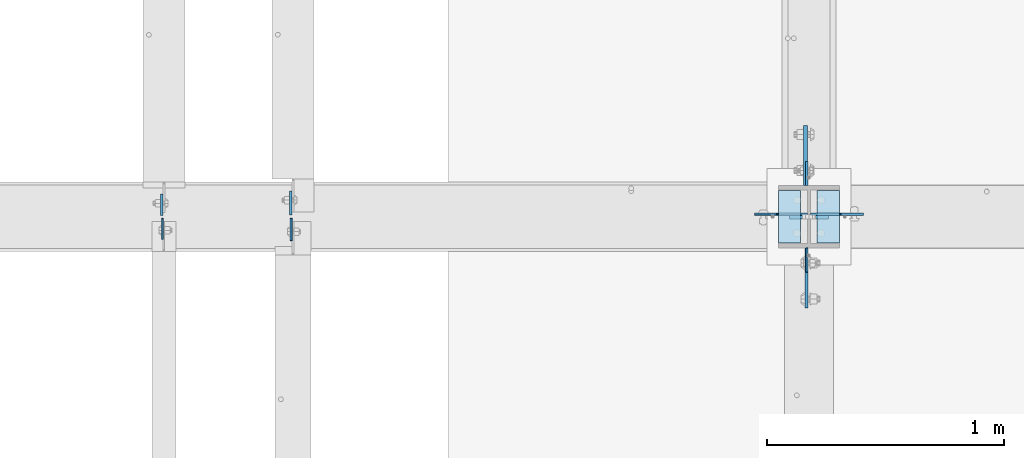
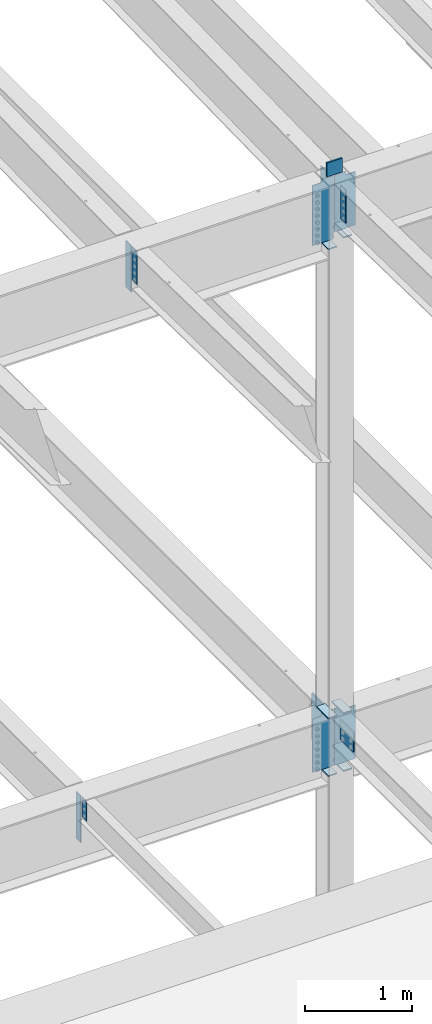
# One storey, part 1544 of 1763: 19 plates, 3 elements without a shape of their own.
"""IFC2X3 building model written with IfcOpenShell, lengths in millimetres."""

from ifc_helpers import new_model, si_unit, frame, origin_with_axes, place, context, subcontext, project, spatial, faceted_brep, material, type_object, element, aggregate, save


model = new_model("IFC2X3")

# Units and contexts
model_context = context("Model", 3, precision=1e-05, world=origin_with_axes())
body_context = subcontext(model_context, "Body", "Model", "MODEL_VIEW")
ifc_project = project(units=[si_unit("LENGTHUNIT", "METRE", prefix="MILLI"), si_unit("AREAUNIT", "SQUARE_METRE"), si_unit("VOLUMEUNIT", "CUBIC_METRE"), si_unit("MASSUNIT", "GRAM", prefix="KILO"), si_unit("TIMEUNIT", "SECOND"), si_unit("PLANEANGLEUNIT", "RADIAN"), si_unit("SOLIDANGLEUNIT", "STERADIAN"), si_unit("THERMODYNAMICTEMPERATUREUNIT", "DEGREE_CELSIUS"), si_unit("LUMINOUSINTENSITYUNIT", "LUMEN")], contexts=[model_context])

# Site, building, storey
site_placement = place(None, origin_with_axes())
site = spatial("IfcSite", under=ifc_project, at=site_placement, CompositionType="ELEMENT")
building_placement = place(site_placement, origin_with_axes())
building = spatial("IfcBuilding", under=site, at=building_placement, Name="Undefined", CompositionType="ELEMENT")
storey_placement = place(building_placement, origin_with_axes())
storey = spatial("IfcBuildingStorey", under=building, at=storey_placement, Name="Undefined", CompositionType="ELEMENT", Elevation=0.0)

# Assembly, plate
assembly_1_placement = place(storey_placement, origin_with_axes())
assembly_1 = element("IfcElementAssembly", 1, at=assembly_1_placement, inside=storey, Name="COLUMN", AssemblyPlace="NOTDEFINED", PredefinedType="RIGID_FRAME")
ifc_material_1 = material(Name="STEEL/A36")
plate_type_1 = type_object("IfcPlateType", PredefinedType="NOTDEFINED")
plate_1_placement = place(assembly_1_placement, frame((-61602.3750236983, 29891.0374999998, 11256.2654896847), z_axis=(0.0, -1.0, 0.0), x_axis=(0.0, 0.0, -1.0)))
plate_1 = element("IfcPlate", 2, at=plate_1_placement, type_object=plate_type_1, material=ifc_material_1, Name="PLATE", context=body_context, shape_type="Brep", body=[
    faceted_brep([(0.0, -3.96900000000096, 0.0), (-1.18234311230481e-11, -3.96900000000096, 101.599998474121), (-1.18234311230481e-11, 3.96900000000096, 101.599998474121), (0.0, 3.96900000000096, 0.0), (381.0, -3.96899999999732, 101.599998474121), (381.0, 3.96899999999732, 101.599998474121), (381.0, -3.96900000001915, 3.34694050252438e-10), (381.0, 3.9690000000046, 3.20142135024071e-10)], [[[0, 1, 2, 3]], [[1, 4, 5, 2]], [[4, 6, 7, 5]], [[6, 0, 3, 7]], [[5, 7, 3, 2]], [[6, 4, 1, 0]]]),
])

# Assembly, plates
assembly_2_placement = place(storey_placement, origin_with_axes())
assembly_2 = element("IfcElementAssembly", 3, at=assembly_2_placement, inside=storey, Name="BEAM", AssemblyPlace="NOTDEFINED", PredefinedType="RIGID_FRAME")
plate_type_2 = type_object("IfcPlateType", PredefinedType="NOTDEFINED")
plate_2_placement = place(assembly_2_placement, frame((-64328.1122736983, 30029.15, 5143.5), z_axis=(0.0, 1.0, 0.0), x_axis=(0.0, 0.0, -1.0)))
plate_2 = element("IfcPlate", 4, at=plate_2_placement, type_object=plate_type_2, material=ifc_material_1, Name="PLATE", context=body_context, shape_type="Brep", body=[
    faceted_brep([(0.0, -4.76249999999982, 0.0), (0.0, -4.76250000000073, 88.9000015258789), (0.0, 4.76250000000073, 88.9000015258789), (0.0, 4.76249999999982, 0.0), (533.400024414062, -4.76250000000073, 88.9000015258789), (533.400024414062, 4.76250000000073, 88.9000015258789), (533.400024414062, -4.76250000000073, 0.0), (533.400024414062, 4.76250000000073, 0.0)], [[[0, 1, 2, 3]], [[1, 4, 5, 2]], [[4, 6, 7, 5]], [[6, 0, 3, 7]], [[5, 7, 3, 2]], [[6, 4, 1, 0]]]),
])
plate_type_3 = type_object("IfcPlateType", PredefinedType="NOTDEFINED")
plate_3_placement = place(assembly_2_placement, frame((-64324.9372736984, 30016.45, 5143.5), z_axis=(0.0, -1.0, 0.0), x_axis=(0.0, 0.0, -1.0)))
plate_3 = element("IfcPlate", 5, at=plate_3_placement, type_object=plate_type_3, material=ifc_material_1, Name="PLATE", context=body_context, shape_type="Brep", body=[
    faceted_brep([(1.81898940354586e-12, -3.17500000000291, 0.0), (0.0, -3.17499999999927, 88.9000015258789), (0.0, 3.17499999999927, 88.9000015258789), (-1.81898940354586e-12, 3.17499999997381, 0.0), (228.600006103516, -3.17499999999927, 88.9000015258789), (228.600006103516, 3.17499999999927, 88.9000015258789), (228.600006103516, -3.17500000001019, -7.27595761418343e-12), (228.600006103516, 3.17499999999563, -7.27595761418343e-12)], [[[0, 1, 2, 3]], [[1, 4, 5, 2]], [[4, 6, 7, 5]], [[6, 0, 3, 7]], [[5, 7, 3, 2]], [[6, 4, 1, 0]]]),
])
aggregate(assembly_2, [plate_2, plate_3])

# Plate
ifc_material_2 = material(Name="STEEL/A572-50")
plate_type_4 = type_object("IfcPlateType", PredefinedType="NOTDEFINED")
plate_4_placement = place(assembly_1_placement, frame((-61511.8872721725, 30022.8000001452, 11455.3999938917), z_axis=(0.0, 0.0, -1.0), x_axis=(-1.0, 0.0, 0.0)))
plate_4 = element("IfcPlate", 6, at=plate_4_placement, type_object=plate_type_4, material=ifc_material_2, Name="PLATE", context=body_context, shape_type="Brep", body=[
    faceted_brep([(7.27595761418343e-12, 9.52500000000146, 155.574990844727), (-1.45519152283669e-11, 7.27595761418343e-12, 165.099990844727), (165.099990844727, 0.0, 165.099990844727), (165.099990844727, 9.52500000000146, 155.574990844727), (-3.63797880709171e-11, -9.5249999999869, 155.574990844727), (165.099990844727, -9.52500000000146, 155.574990844727), (0.0, 9.52500000000146, 0.0), (0.0, -9.52500000000146, 0.0), (165.099990844727, -9.52500000000146, 0.0), (165.099990844727, 9.52500000000146, 0.0)], [[[0, 1, 2, 3]], [[1, 4, 5, 2]], [[6, 7, 4, 1, 0]], [[5, 8, 9, 3, 2]], [[8, 7, 6, 9]], [[9, 6, 0, 3]], [[7, 8, 5, 4]]]),
])

plate_type_5 = type_object("IfcPlateType", PredefinedType="NOTDEFINED")
plate_5_placement = place(assembly_1_placement, frame((-61603.9622736984, 30154.5624999999, 11256.2236063034), z_axis=(0.0, 1.0, 0.0), x_axis=(0.0, 0.0, -1.0)))
plate_5 = element("IfcPlate", 7, at=plate_5_placement, type_object=plate_type_5, material=ifc_material_1, Name="PLATE", context=body_context, shape_type="Brep", body=[
    faceted_brep([(0.0, -4.76249999999982, 0.0), (1.45519152283669e-11, -4.76250000000448, 101.60001373291), (0.0, 4.76250000000243, 101.60001373291), (0.0, 4.76249999999982, 0.0), (533.400024414062, -4.76249999999709, 101.599998474121), (533.400024414062, 4.76249999999709, 101.599998474121), (533.400024414062, -4.76250000000073, 0.0), (533.400024414062, 4.76250000000073, 0.0)], [[[0, 1, 2, 3]], [[1, 4, 5, 2]], [[4, 6, 7, 5]], [[6, 0, 3, 7]], [[5, 7, 3, 2]], [[6, 4, 1, 0]]]),
])

# Assembly, plate
assembly_3_placement = place(storey_placement, origin_with_axes())
assembly_3 = element("IfcElementAssembly", 8, at=assembly_3_placement, inside=storey, Name="BEAM", AssemblyPlace="NOTDEFINED", PredefinedType="RIGID_FRAME")
plate_6_placement = place(assembly_3_placement, frame((-63783.2822736984, 30029.9437498557, 11240.9425694796), z_axis=(0.0, 1.0, 0.0), x_axis=(0.0, 0.0, -1.0)))
plate_6 = element("IfcPlate", 9, at=plate_6_placement, type_object=plate_type_5, material=ifc_material_1, Name="PLATE", context=body_context, shape_type="Brep", body=[
    faceted_brep([(0.0, -4.76249999999982, 0.0), (1.45519152283669e-11, -4.76250000000448, 101.60001373291), (0.0, 4.76250000000243, 101.60001373291), (0.0, 4.76249999999982, 0.0), (533.400024414062, -4.76249999999709, 101.599998474121), (533.400024414062, 4.76249999999709, 101.599998474121), (533.400024414062, -4.76250000000073, 0.0), (533.400024414062, 4.76250000000073, 0.0)], [[[0, 1, 2, 3]], [[1, 4, 5, 2]], [[4, 6, 7, 5]], [[6, 0, 3, 7]], [[5, 7, 3, 2]], [[6, 4, 1, 0]]]),
])

# Plate
plate_type_6 = type_object("IfcPlateType", PredefinedType="NOTDEFINED")
plate_7_placement = place(assembly_1_placement, frame((-61465.8497736983, 29911.675, 10623.4838553193), z_axis=(0.0, 1.0, 0.0), x_axis=(-1.0, 0.0, 0.0)))
plate_7 = element("IfcPlate", 10, at=plate_7_placement, type_object=plate_type_6, material=ifc_material_1, Name="PLATE", context=body_context, shape_type="Brep", body=[
    faceted_brep([(0.0, -6.34999999999491, 1.45519152283669e-11), (0.0, -6.35000000000036, 222.25), (0.0, 6.35000000000036, 222.25), (0.0, 6.34999999999491, -2.91038304567337e-11), (93.6624984741211, -6.35000000000036, 222.25), (93.6624984741211, 6.35000000000036, 222.25), (93.6624984741211, -6.35000000000036, 0.0), (93.6624984741211, 6.35000000000036, 0.0)], [[[0, 1, 2, 3]], [[1, 4, 5, 2]], [[4, 6, 7, 5]], [[6, 0, 3, 7]], [[5, 7, 3, 2]], [[6, 4, 1, 0]]]),
])

plate_8_placement = place(assembly_1_placement, frame((-61723.0247736983, 30133.925, 10547.2838431128), z_axis=(0.0, -1.0, 0.0), x_axis=(1.0, 0.0, 0.0)))
plate_8 = element("IfcPlate", 11, at=plate_8_placement, type_object=plate_type_6, material=ifc_material_1, Name="PLATE", context=body_context, shape_type="Brep", body=[
    faceted_brep([(0.0, -6.34999999999491, 1.45519152283669e-11), (0.0, -6.35000000000036, 222.25), (0.0, 6.35000000000036, 222.25), (0.0, 6.34999999999491, -2.91038304567337e-11), (93.6624984741211, -6.35000000000036, 222.25), (93.6624984741211, 6.35000000000036, 222.25), (93.6624984741211, -6.35000000000036, 0.0), (93.6624984741211, 6.35000000000036, 0.0)], [[[0, 1, 2, 3]], [[1, 4, 5, 2]], [[4, 6, 7, 5]], [[6, 0, 3, 7]], [[5, 7, 3, 2]], [[6, 4, 1, 0]]]),
])

plate_9_placement = place(assembly_1_placement, frame((-61723.0247736983, 30133.925, 4527.54998779297), z_axis=(0.0, -1.0, 0.0), x_axis=(1.0, 0.0, 0.0)))
plate_9 = element("IfcPlate", 12, at=plate_9_placement, type_object=plate_type_6, material=ifc_material_1, Name="PLATE", context=body_context, shape_type="Brep", body=[
    faceted_brep([(0.0, -6.34999999999491, 1.45519152283669e-11), (0.0, -6.35000000000036, 222.25), (0.0, 6.35000000000036, 222.25), (0.0, 6.34999999999491, -2.91038304567337e-11), (93.6624984741211, -6.35000000000036, 222.25), (93.6624984741211, 6.35000000000036, 222.25), (93.6624984741211, -6.35000000000036, 0.0), (93.6624984741211, 6.35000000000036, 0.0)], [[[0, 1, 2, 3]], [[1, 4, 5, 2]], [[4, 6, 7, 5]], [[6, 0, 3, 7]], [[5, 7, 3, 2]], [[6, 4, 1, 0]]]),
])

plate_10_placement = place(assembly_1_placement, frame((-61723.0247736983, 30133.925, 5187.95), z_axis=(0.0, -1.0, 0.0), x_axis=(1.0, 0.0, 0.0)))
plate_10 = element("IfcPlate", 13, at=plate_10_placement, type_object=plate_type_6, material=ifc_material_1, Name="PLATE", context=body_context, shape_type="Brep", body=[
    faceted_brep([(0.0, -6.34999999999491, 1.45519152283669e-11), (0.0, -6.35000000000036, 222.25), (0.0, 6.35000000000036, 222.25), (0.0, 6.34999999999491, -2.91038304567337e-11), (93.6624984741211, -6.35000000000036, 222.25), (93.6624984741211, 6.35000000000036, 222.25), (93.6624984741211, -6.35000000000036, 0.0), (93.6624984741211, 6.35000000000036, 0.0)], [[[0, 1, 2, 3]], [[1, 4, 5, 2]], [[4, 6, 7, 5]], [[6, 0, 3, 7]], [[5, 7, 3, 2]], [[6, 4, 1, 0]]]),
])

plate_11_placement = place(assembly_1_placement, frame((-61465.8497736983, 29911.675, 4527.54998779297), z_axis=(0.0, 1.0, 0.0), x_axis=(-1.0, 0.0, 0.0)))
plate_11 = element("IfcPlate", 14, at=plate_11_placement, type_object=plate_type_6, material=ifc_material_1, Name="PLATE", context=body_context, shape_type="Brep", body=[
    faceted_brep([(0.0, -6.34999999999491, 1.45519152283669e-11), (0.0, -6.35000000000036, 222.25), (0.0, 6.35000000000036, 222.25), (0.0, 6.34999999999491, -2.91038304567337e-11), (93.6624984741211, -6.35000000000036, 222.25), (93.6624984741211, 6.35000000000036, 222.25), (93.6624984741211, -6.35000000000036, 0.0), (93.6624984741211, 6.35000000000036, 0.0)], [[[0, 1, 2, 3]], [[1, 4, 5, 2]], [[4, 6, 7, 5]], [[6, 0, 3, 7]], [[5, 7, 3, 2]], [[6, 4, 1, 0]]]),
])

plate_12_placement = place(assembly_1_placement, frame((-61465.8497736983, 29911.675, 5187.95), z_axis=(0.0, 1.0, 0.0), x_axis=(-1.0, 0.0, 0.0)))
plate_12 = element("IfcPlate", 15, at=plate_12_placement, type_object=plate_type_6, material=ifc_material_1, Name="PLATE", context=body_context, shape_type="Brep", body=[
    faceted_brep([(0.0, -6.34999999999491, 1.45519152283669e-11), (0.0, -6.35000000000036, 222.25), (0.0, 6.35000000000036, 222.25), (0.0, 6.34999999999491, -2.91038304567337e-11), (93.6624984741211, -6.35000000000036, 222.25), (93.6624984741211, 6.35000000000036, 222.25), (93.6624984741211, -6.35000000000036, 0.0), (93.6624984741211, 6.35000000000036, 0.0)], [[[0, 1, 2, 3]], [[1, 4, 5, 2]], [[4, 6, 7, 5]], [[6, 0, 3, 7]], [[5, 7, 3, 2]], [[6, 4, 1, 0]]]),
])

plate_type_7 = type_object("IfcPlateType", PredefinedType="NOTDEFINED")
plate_13_placement = place(assembly_1_placement, frame((-61605.5497736983, 29891.0375, 5156.2), z_axis=(0.0, -1.0, 0.0), x_axis=(0.0, 0.0, -1.0)))
plate_13 = element("IfcPlate", 16, at=plate_13_placement, type_object=plate_type_7, material=ifc_material_2, Name="PLATE", context=body_context, shape_type="Brep", body=[
    faceted_brep([(0.0, -6.34999999999491, 1.45519152283669e-11), (0.0, -6.34999999999854, 254.0), (0.0, 6.34999999999854, 254.0), (0.0, 6.34999999999491, -2.91038304567337e-11), (228.600006103516, -6.34999999999854, 254.0), (228.600006103516, 6.34999999999854, 254.0), (228.600006103565, -6.34999999936554, -7.49423634260893e-10), (228.600006103557, 6.35000000064611, -7.13043846189976e-10)], [[[0, 1, 2, 3]], [[1, 4, 5, 2]], [[4, 6, 7, 5]], [[6, 0, 3, 7]], [[5, 7, 3, 2]], [[6, 4, 1, 0]]]),
])

plate_type_8 = type_object("IfcPlateType", PredefinedType="NOTDEFINED")
plate_14_placement = place(assembly_1_placement, frame((-61608.7247736983, 30154.5625, 5143.5), z_axis=(0.0, 1.0, 0.0), x_axis=(0.0, 0.0, -1.0)))
plate_14 = element("IfcPlate", 17, at=plate_14_placement, type_object=plate_type_8, material=ifc_material_2, Name="PLATE", context=body_context, shape_type="Brep", body=[
    faceted_brep([(-7.27595761418343e-12, -7.9375, 0.0), (0.0, -7.9375, 254.0), (0.0, 7.9375, 254.0), (-7.27595761418343e-12, 7.9375, 0.0), (533.400024414062, -7.9375, 254.0), (533.400024414062, 7.9375, 254.0), (533.400024414062, -7.9375, 0.0), (533.400024414062, 7.9375, 0.0)], [[[0, 1, 2, 3]], [[1, 4, 5, 2]], [[4, 6, 7, 5]], [[6, 0, 3, 7]], [[5, 7, 3, 2]], [[6, 4, 1, 0]]]),
])

plate_type_9 = type_object("IfcPlateType", PredefinedType="NOTDEFINED")
plate_15_placement = place(assembly_1_placement, frame((-61588.0872736983, 30033.9124998712, 11277.5338675263), z_axis=(1.0, 0.0, 0.0), x_axis=(0.0, 0.0, -1.0)))
plate_15 = element("IfcPlate", 18, at=plate_15_placement, type_object=plate_type_9, material=ifc_material_1, Name="PLATE", context=body_context, shape_type="Brep", body=[
    faceted_brep([(25.4000001907334, -4.76250000000073, 122.237503051758), (25.4000001907334, 4.76250000000073, 122.237503051758), (-2.5465851649642e-11, 4.76250000019581, 122.237500000236), (-3.45607986673713e-11, -4.76249999983202, 122.23750000025), (30.2600797087798, -4.76250000000073, 123.204232974349), (30.2600797087798, 4.76250000000073, 123.204232974349), (34.3802561769335, -4.76250000000073, 125.957246874823), (34.3802561769335, 4.76250000000073, 125.957246874823), (37.133270077411, -4.76250000000073, 130.077423342977), (37.133270077411, 4.76250000000073, 130.077423342977), (38.0999999999985, -4.76250000000073, 134.937502861023), (38.0999999999985, 4.76250000000073, 134.937502861023), (38.0999999999985, -4.76250000000073, 223.837493896484), (38.0999999999985, 4.76250000000073, 223.837493896484), (647.700012207031, -4.76250000000073, 0.0), (0.0, -4.76249999999982, 0.0), (0.0, 4.76249999999982, 0.0), (647.700012207031, 4.76250000000073, 0.0), (647.700012207031, -4.76250000000073, 223.837493896484), (647.700012207031, 4.76250000000073, 223.837493896484)], [[[0, 1, 2, 3]], [[4, 5, 1, 0]], [[6, 7, 5, 4]], [[8, 9, 7, 6]], [[10, 11, 9, 8]], [[12, 13, 11, 10]], [[14, 15, 16, 17]], [[18, 14, 17, 19]], [[8, 6, 4, 0, 3, 15, 14, 18, 12, 10]], [[16, 15, 3, 2]], [[19, 17, 16, 2, 1, 5, 7, 9, 11, 13]], [[18, 19, 13, 12]]]),
])

plate_16_placement = place(assembly_1_placement, frame((-61600.7872736983, 30034.7062498557, 11277.5338675269), z_axis=(-1.0, 0.0, 0.0), x_axis=(0.0, 0.0, -1.0)))
plate_16 = element("IfcPlate", 19, at=plate_16_placement, type_object=plate_type_9, material=ifc_material_1, Name="PLATE", context=body_context, shape_type="Brep", body=[
    faceted_brep([(25.4000001907334, -4.76250000000073, 122.237503051758), (25.4000001907334, 4.76250000000073, 122.237503051758), (-2.5465851649642e-11, 4.76250000019581, 122.237500000236), (-3.45607986673713e-11, -4.76249999983202, 122.23750000025), (30.2600797087798, -4.76250000000073, 123.204232974349), (30.2600797087798, 4.76250000000073, 123.204232974349), (34.3802561769335, -4.76250000000073, 125.957246874823), (34.3802561769335, 4.76250000000073, 125.957246874823), (37.133270077411, -4.76250000000073, 130.077423342977), (37.133270077411, 4.76250000000073, 130.077423342977), (38.0999999999985, -4.76250000000073, 134.937502861023), (38.0999999999985, 4.76250000000073, 134.937502861023), (38.0999999999985, -4.76250000000073, 223.837493896484), (38.0999999999985, 4.76250000000073, 223.837493896484), (723.900024414062, -4.76250000000073, 0.0), (0.0, -4.76249999999982, 0.0), (0.0, 4.76249999999982, 0.0), (723.900024414062, 4.76250000000073, 0.0), (723.900024414062, -4.76250000000073, 223.837493896484), (723.900024414062, 4.76250000000073, 223.837493896484)], [[[0, 1, 2, 3]], [[4, 5, 1, 0]], [[6, 7, 5, 4]], [[8, 9, 7, 6]], [[10, 11, 9, 8]], [[12, 13, 11, 10]], [[14, 15, 16, 17]], [[18, 14, 17, 19]], [[8, 6, 4, 0, 3, 15, 14, 18, 12, 10]], [[16, 15, 3, 2]], [[19, 17, 16, 2, 1, 5, 7, 9, 11, 13]], [[18, 19, 13, 12]]]),
])

plate_17_placement = place(assembly_1_placement, frame((-61600.7872736983, 30033.9125, 5181.6), z_axis=(-1.0, 0.0, 0.0), x_axis=(0.0, 0.0, -1.0)))
plate_17 = element("IfcPlate", 20, at=plate_17_placement, type_object=plate_type_9, material=ifc_material_1, Name="PLATE", context=body_context, shape_type="Brep", body=[
    faceted_brep([(25.4000001907334, -4.76250000000073, 122.237503051758), (25.4000001907334, 4.76250000000073, 122.237503051758), (-2.5465851649642e-11, 4.76250000019581, 122.237500000236), (-3.45607986673713e-11, -4.76249999983202, 122.23750000025), (30.2600797087798, -4.76250000000073, 123.204232974349), (30.2600797087798, 4.76250000000073, 123.204232974349), (34.3802561769335, -4.76250000000073, 125.957246874823), (34.3802561769335, 4.76250000000073, 125.957246874823), (37.133270077411, -4.76250000000073, 130.077423342977), (37.133270077411, 4.76250000000073, 130.077423342977), (38.0999999999985, -4.76250000000073, 134.937502861023), (38.0999999999985, 4.76250000000073, 134.937502861023), (38.0999999999985, -4.76250000000073, 223.837493896484), (38.0999999999985, 4.76250000000073, 223.837493896484), (647.700012207031, -4.76250000000073, 0.0), (0.0, -4.76249999999982, 0.0), (0.0, 4.76249999999982, 0.0), (647.700012207031, 4.76250000000073, 0.0), (647.700012207031, -4.76250000000073, 223.837493896484), (647.700012207031, 4.76250000000073, 223.837493896484)], [[[0, 1, 2, 3]], [[4, 5, 1, 0]], [[6, 7, 5, 4]], [[8, 9, 7, 6]], [[10, 11, 9, 8]], [[12, 13, 11, 10]], [[14, 15, 16, 17]], [[18, 14, 17, 19]], [[8, 6, 4, 0, 3, 15, 14, 18, 12, 10]], [[16, 15, 3, 2]], [[19, 17, 16, 2, 1, 5, 7, 9, 11, 13]], [[18, 19, 13, 12]]]),
])

plate_18_placement = place(assembly_1_placement, frame((-61588.0872736983, 30033.9125, 5181.6), z_axis=(1.0, 0.0, 0.0), x_axis=(0.0, 0.0, -1.0)))
plate_18 = element("IfcPlate", 21, at=plate_18_placement, type_object=plate_type_9, material=ifc_material_1, Name="PLATE", context=body_context, shape_type="Brep", body=[
    faceted_brep([(25.4000001907334, -4.76250000000073, 122.237503051758), (25.4000001907334, 4.76250000000073, 122.237503051758), (-2.5465851649642e-11, 4.76250000019581, 122.237500000236), (-3.45607986673713e-11, -4.76249999983202, 122.23750000025), (30.2600797087798, -4.76250000000073, 123.204232974349), (30.2600797087798, 4.76250000000073, 123.204232974349), (34.3802561769335, -4.76250000000073, 125.957246874823), (34.3802561769335, 4.76250000000073, 125.957246874823), (37.133270077411, -4.76250000000073, 130.077423342977), (37.133270077411, 4.76250000000073, 130.077423342977), (38.0999999999985, -4.76250000000073, 134.937502861023), (38.0999999999985, 4.76250000000073, 134.937502861023), (38.0999999999985, -4.76250000000073, 223.837493896484), (38.0999999999985, 4.76250000000073, 223.837493896484), (647.700012207031, -4.76250000000073, 0.0), (0.0, -4.76249999999982, 0.0), (0.0, 4.76249999999982, 0.0), (647.700012207031, 4.76250000000073, 0.0), (647.700012207031, -4.76250000000073, 223.837493896484), (647.700012207031, 4.76250000000073, 223.837493896484)], [[[0, 1, 2, 3]], [[4, 5, 1, 0]], [[6, 7, 5, 4]], [[8, 9, 7, 6]], [[10, 11, 9, 8]], [[12, 13, 11, 10]], [[14, 15, 16, 17]], [[18, 14, 17, 19]], [[8, 6, 4, 0, 3, 15, 14, 18, 12, 10]], [[16, 15, 3, 2]], [[19, 17, 16, 2, 1, 5, 7, 9, 11, 13]], [[18, 19, 13, 12]]]),
])

aggregate(assembly_1, [plate_4, plate_7, plate_15, plate_8, plate_16, plate_1, plate_5, plate_9, plate_10, plate_17, plate_11, plate_12, plate_18, plate_13, plate_14])

plate_type_10 = type_object("IfcPlateType", PredefinedType="NOTDEFINED")
plate_19_placement = place(assembly_3_placement, frame((-63781.6950236983, 30015.6562498557, 11239.2036569038), z_axis=(0.0, -1.0, 0.0), x_axis=(0.0, 0.0, -1.0)))
plate_19 = element("IfcPlate", 22, at=plate_19_placement, type_object=plate_type_10, material=ifc_material_1, Name="PLATE", context=body_context, shape_type="Brep", body=[
    faceted_brep([(0.0, -3.96900000000096, 0.0), (0.0, -3.96899999999732, 93.6624984741211), (0.0, 3.96899999999732, 93.6624984741211), (0.0, 3.96900000000096, 0.0), (381.0, -3.96899999999732, 93.6624984741211), (381.0, 3.96899999999732, 93.6624984741211), (381.0, -3.96900000001915, 3.34694050252438e-10), (381.0, 3.9690000000046, 3.20142135024071e-10)], [[[0, 1, 2, 3]], [[1, 4, 5, 2]], [[4, 6, 7, 5]], [[6, 0, 3, 7]], [[5, 7, 3, 2]], [[6, 4, 1, 0]]]),
])

aggregate(assembly_3, [plate_19, plate_6])

save(model, "model.ifc")
